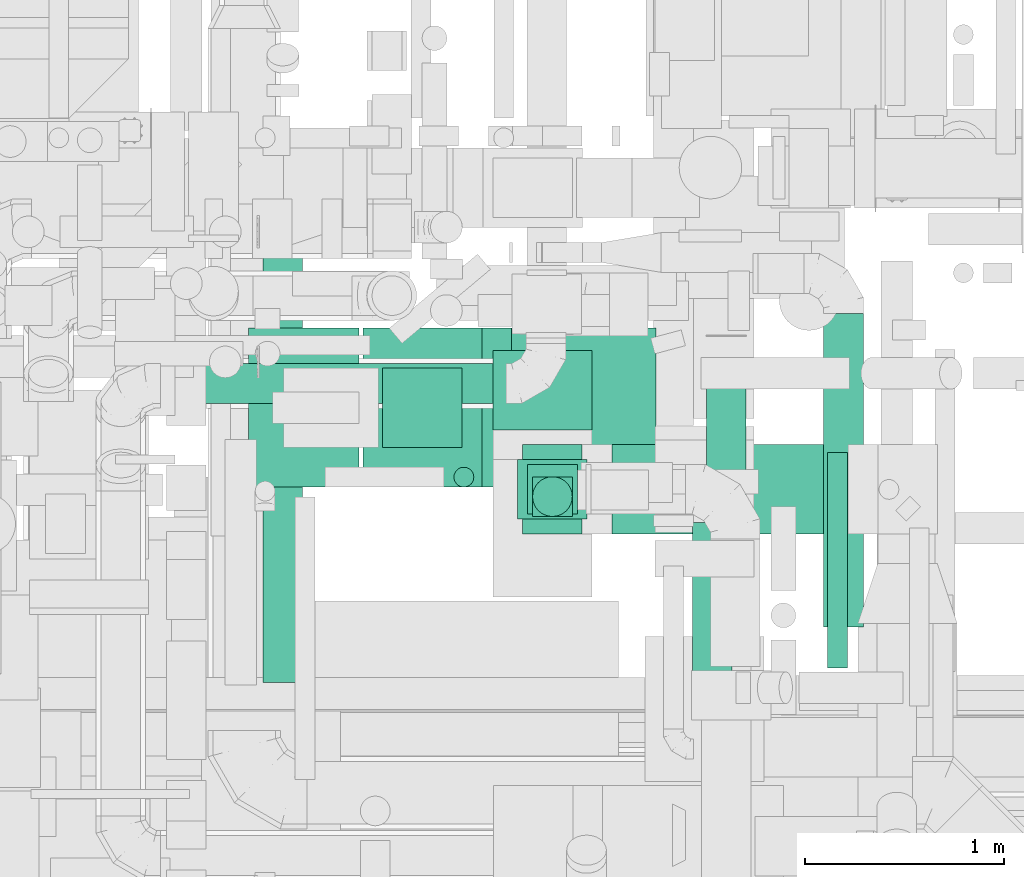
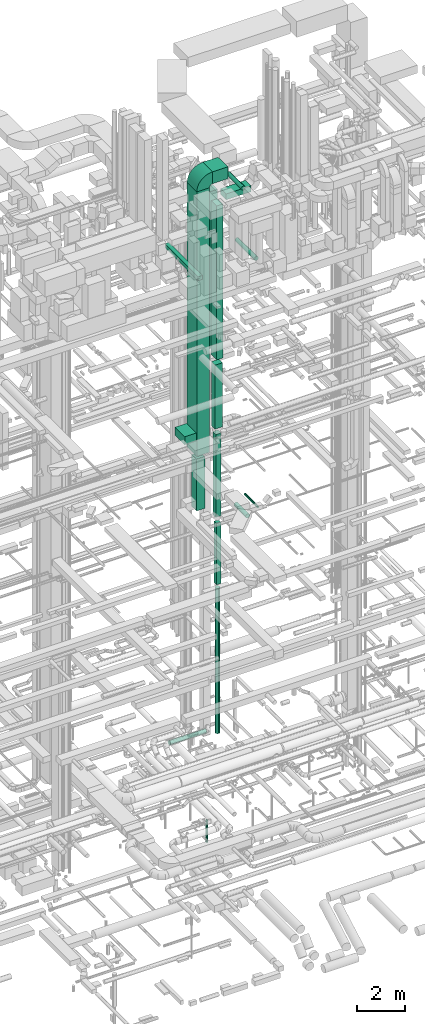
# One storey, part 45 of 337: 18 flow segments, 1 flow fitting.
"""IFC2X3 building model written with IfcOpenShell, lengths in millimetres."""

from ifc_helpers import new_model, entity, si_unit, converted_unit, derived_unit, direction, frame, frame_2d, origin, origin_2d_with_axis, place, context, subcontext, project, spatial, polyline, circle_curve, parameter, trimmed, segment, composite_curve, rectangle, circle, outline, extrude, source, transform, mapped, material, type_object, type_shapes, element, save


model = new_model("IFC2X3")

# Units and contexts
model_context = context("Model", 3, precision=0.01, world=origin(), true_north=direction((6.12303176911189e-17, 1.0)))
body_context = subcontext(model_context, "Body", "Model", "MODEL_VIEW")
ifc_project = project(units=[si_unit("LENGTHUNIT", "METRE", prefix="MILLI"), si_unit("AREAUNIT", "SQUARE_METRE"), si_unit("VOLUMEUNIT", "CUBIC_METRE"), converted_unit("PLANEANGLEUNIT", "DEGREE", entity("IfcRatioMeasure", 0.0174532925199433), si_unit("PLANEANGLEUNIT", "RADIAN"), dimensions=[0, 0, 0, 0, 0, 0, 0]), si_unit("MASSUNIT", "GRAM", prefix="KILO"), derived_unit("MASSDENSITYUNIT", [(si_unit("MASSUNIT", "GRAM", prefix="KILO"), 1), (si_unit("LENGTHUNIT", "METRE"), -3)]), derived_unit("MOMENTOFINERTIAUNIT", [(si_unit("LENGTHUNIT", "METRE"), 4)]), si_unit("TIMEUNIT", "SECOND"), si_unit("FREQUENCYUNIT", "HERTZ"), si_unit("THERMODYNAMICTEMPERATUREUNIT", "DEGREE_CELSIUS"), derived_unit("THERMALTRANSMITTANCEUNIT", [(si_unit("MASSUNIT", "GRAM", prefix="KILO"), 1), (si_unit("THERMODYNAMICTEMPERATUREUNIT", "KELVIN"), -1), (si_unit("TIMEUNIT", "SECOND"), -3)]), derived_unit("VOLUMETRICFLOWRATEUNIT", [(si_unit("LENGTHUNIT", "METRE"), 3), (si_unit("TIMEUNIT", "SECOND"), -1)]), derived_unit("MASSFLOWRATEUNIT", [(si_unit("MASSUNIT", "GRAM", prefix="KILO"), 1), (si_unit("TIMEUNIT", "SECOND"), -1)]), derived_unit("ROTATIONALFREQUENCYUNIT", [(si_unit("TIMEUNIT", "SECOND"), -1)]), si_unit("ELECTRICCURRENTUNIT", "AMPERE"), si_unit("ELECTRICVOLTAGEUNIT", "VOLT"), si_unit("POWERUNIT", "WATT"), si_unit("FORCEUNIT", "NEWTON", prefix="KILO"), si_unit("ILLUMINANCEUNIT", "LUX"), si_unit("LUMINOUSFLUXUNIT", "LUMEN"), si_unit("LUMINOUSINTENSITYUNIT", "CANDELA"), derived_unit("USERDEFINED", [(si_unit("MASSUNIT", "GRAM", prefix="KILO"), -1), (si_unit("LENGTHUNIT", "METRE"), -2), (si_unit("TIMEUNIT", "SECOND"), 3), (si_unit("LUMINOUSFLUXUNIT", "LUMEN"), 1)]), derived_unit("LINEARVELOCITYUNIT", [(si_unit("LENGTHUNIT", "METRE"), 1), (si_unit("TIMEUNIT", "SECOND"), -1)]), si_unit("PRESSUREUNIT", "PASCAL"), derived_unit("USERDEFINED", [(si_unit("LENGTHUNIT", "METRE"), -2), (si_unit("MASSUNIT", "GRAM", prefix="KILO"), 1), (si_unit("TIMEUNIT", "SECOND"), -2)]), derived_unit("LINEARFORCEUNIT", [(si_unit("MASSUNIT", "GRAM", prefix="KILO"), 1), (si_unit("LENGTHUNIT", "METRE"), 1), (si_unit("TIMEUNIT", "SECOND"), -2), (si_unit("LENGTHUNIT", "METRE"), -1)]), derived_unit("PLANARFORCEUNIT", [(si_unit("MASSUNIT", "GRAM", prefix="KILO"), 1), (si_unit("LENGTHUNIT", "METRE"), 1), (si_unit("TIMEUNIT", "SECOND"), -2), (si_unit("LENGTHUNIT", "METRE"), -2)])], contexts=[model_context])

# Site, building, storey
site_placement = place(None, origin())
site = spatial("IfcSite", under=ifc_project, at=site_placement, CompositionType="ELEMENT")
building_placement = place(site_placement, origin())
building = spatial("IfcBuilding", under=site, at=building_placement, CompositionType="ELEMENT")
storey_placement = place(building_placement, origin())
storey = spatial("IfcBuildingStorey", under=building, at=storey_placement, CompositionType="ELEMENT", Elevation=0.0)

# Flow segments
duct_segment_type_1 = type_object("IfcDuctSegmentType", PredefinedType="NOTDEFINED")
flow_segment_1_placement = place(storey_placement, frame((52500.03, 11137.23, 11150.0)))
element("IfcFlowSegment", 1, at=flow_segment_1_placement, inside=storey, type_object=duct_segment_type_1, context=body_context, shape_type="SweptSolid", body=[
    extrude(rectangle(XDim=200.000000000007, YDim=200.0, at=origin_2d_with_axis()), frame((100.0, 100.0, 0.0)), (0.0, 0.0, 1.0), 3100.00000000006),
])
flow_segment_2_placement = place(storey_placement, frame((51070.03, 11285.33, 18620.0)))
element("IfcFlowSegment", 2, at=flow_segment_2_placement, inside=storey, type_object=duct_segment_type_1, context=body_context, shape_type="SweptSolid", body=[
    extrude(rectangle(XDim=555.179984898517, YDim=800.0, at=origin_2d_with_axis()), frame((277.59, 400.0, 0.0)), (0.0, 0.0, 1.0), 400.0),
])
flow_segment_3_placement = place(storey_placement, frame((51645.21, 11285.34, 17827.47)))
element("IfcFlowSegment", 3, at=flow_segment_3_placement, inside=storey, type_object=duct_segment_type_1, context=body_context, shape_type="SweptSolid", body=[
    extrude(rectangle(XDim=600.000000000002, YDim=800.0, at=origin_2d_with_axis()), frame((300.0, 400.0, 0.0), z_axis=(0.0, 0.0, 1.0), x_axis=(-1.0, 0.0, 0.0)), (0.0, 0.0, 1.0), 13322.5290698006),
])
flow_segment_4_placement = place(storey_placement, frame((51745.21, 11485.34, 14927.47)))
element("IfcFlowSegment", 4, at=flow_segment_4_placement, inside=storey, type_object=duct_segment_type_1, context=body_context, shape_type="SweptSolid", body=[
    extrude(rectangle(XDim=399.999999999996, YDim=400.0, at=origin_2d_with_axis()), frame((200.0, 200.0, 0.0), z_axis=(0.0, 0.0, 1.0), x_axis=(-1.0, 0.0, 0.0)), (0.0, 0.0, 1.0), 2600.0),
])
flow_segment_5_placement = place(storey_placement, frame((52475.03, 11149.6, 14550.0)))
element("IfcFlowSegment", 5, at=flow_segment_5_placement, inside=storey, type_object=duct_segment_type_1, context=body_context, shape_type="SweptSolid", body=[
    extrude(rectangle(XDim=249.999999999999, YDim=250.000000000004, at=origin_2d_with_axis()), frame((125.0, 125.0, 0.0), z_axis=(0.0, 0.0, 1.0), x_axis=(0.0, 1.0, 0.0)), (0.0, 0.0, 1.0), 4175.39989839999),
])
flow_segment_6_placement = place(storey_placement, frame((52425.03, 11124.6, 19025.4)))
element("IfcFlowSegment", 6, at=flow_segment_6_placement, inside=storey, type_object=duct_segment_type_1, context=body_context, shape_type="SweptSolid", body=[
    extrude(rectangle(XDim=350.000000000007, YDim=300.000000000001, at=origin_2d_with_axis()), frame((175.0, 150.0, 0.0)), (0.0, 0.0, 1.0), 3224.60010159989),
])
flow_segment_7_placement = place(storey_placement, frame((52300.35, 11573.34, 22801.13)))
element("IfcFlowSegment", 7, at=flow_segment_7_placement, inside=storey, type_object=duct_segment_type_1, context=body_context, shape_type="SweptSolid", body=[
    extrude(rectangle(XDim=500.000000000008, YDim=400.000000000001, at=origin_2d_with_axis()), frame((250.0, 200.3, 0.01)), (0.0, 0.0, 1.0), 7903.89848948778),
])
flow_segment_8_placement = place(storey_placement, frame((51142.9, 10302.41, 27450.0)))
element("IfcFlowSegment", 8, at=flow_segment_8_placement, inside=storey, type_object=duct_segment_type_1, context=body_context, shape_type="SweptSolid", body=[
    extrude(rectangle(XDim=2749.99999999996, YDim=199.999999999998, at=origin_2d_with_axis()), frame((100.0, 1375.0, 0.0), z_axis=(0.0, 0.0, 1.0), x_axis=(0.0, -1.0, 0.0)), (0.0, 0.0, 1.0), 199.999999999998),
])
flow_segment_9_placement = place(storey_placement, frame((52395.21, 11285.34, 31300.0)))
element("IfcFlowSegment", 9, at=flow_segment_9_placement, inside=storey, type_object=duct_segment_type_1, context=body_context, shape_type="SweptSolid", body=[
    extrude(rectangle(XDim=725.900486099132, YDim=800.0, at=origin_2d_with_axis()), frame((362.95, 400.0, 0.0)), (0.0, 0.0, 1.0), 600.000000000002),
])
flow_segment_10_placement = place(storey_placement, frame((52450.03, 11049.6, 22550.0)))
element("IfcFlowSegment", 10, at=flow_segment_10_placement, inside=storey, type_object=duct_segment_type_1, context=body_context, shape_type="SweptSolid", body=[
    extrude(rectangle(XDim=300.000000000001, YDim=449.999999999999, at=origin_2d_with_axis()), frame((150.0, 225.0, 0.0)), (0.0, 0.0, 1.0), 7750.00000000012),
])
flow_segment_11_placement = place(storey_placement, frame((52900.03, 11049.6, 30450.0)))
element("IfcFlowSegment", 11, at=flow_segment_11_placement, inside=storey, type_object=duct_segment_type_1, context=body_context, shape_type="SweptSolid", body=[
    extrude(rectangle(XDim=1187.96669999977, YDim=449.999999999999, at=origin_2d_with_axis()), frame((593.98, 225.0, 0.0), z_axis=(0.0, 0.0, 1.0), x_axis=(-1.0, 0.0, 0.0)), (0.0, 0.0, 1.0), 300.000000000001),
])
duct_segment_type_2 = type_object("IfcDuctSegmentType", PredefinedType="NOTDEFINED")
flow_segment_12_placement = place(storey_placement, frame((52102.68, 11283.75, -1800.53)))
element("IfcFlowSegment", 12, at=flow_segment_12_placement, inside=storey, type_object=duct_segment_type_2, context=body_context, shape_type="SweptSolid", body=[
    extrude(circle(Radius=50.0, at=origin_2d_with_axis()), frame((51.6, 51.6, 0.0), z_axis=(0.0, 0.0, 1.0), x_axis=(-1.0, 0.0, 0.0)), (0.0, 0.0, 1.0), 1100.52558883259),
])
flow_segment_13_placement = place(storey_placement, frame((52498.44, 11135.63, 3630.0)))
element("IfcFlowSegment", 13, at=flow_segment_13_placement, inside=storey, type_object=duct_segment_type_2, context=body_context, shape_type="SweptSolid", body=[
    extrude(circle(Radius=100.0, at=origin_2d_with_axis()), frame((101.6, 101.6, 0.0)), (0.0, 0.0, 1.0), 7319.99999999999),
])
flow_segment_14_placement = place(storey_placement, frame((53303.43, 10130.34, 14818.4)))
element("IfcFlowSegment", 14, at=flow_segment_14_placement, inside=storey, type_object=duct_segment_type_2, context=body_context, shape_type="SweptSolid", body=[
    extrude(circle(Radius=100.0, at=origin_2d_with_axis()), frame((101.6, 0.0, 101.6), z_axis=(0.0, 1.0, 0.0), x_axis=(-1.0, 0.0, 0.0)), (0.0, 0.0, 1.0), 977.430276017839),
])
flow_segment_15_placement = place(storey_placement, frame((53984.44, 10375.04, 14948.4)))
element("IfcFlowSegment", 15, at=flow_segment_15_placement, inside=storey, type_object=duct_segment_type_2, context=body_context, shape_type="SweptSolid", body=[
    extrude(circle(Radius=50.0, at=origin_2d_with_axis()), frame((51.6, 0.0, 51.6), z_axis=(0.0, 1.0, 0.0), x_axis=(1.0, 0.0, 0.0)), (0.0, 0.0, 1.0), 1085.29999999999),
])
flow_segment_16_placement = place(storey_placement, frame((53373.44, 10626.24, 30998.4)))
element("IfcFlowSegment", 16, at=flow_segment_16_placement, inside=storey, type_object=duct_segment_type_2, context=body_context, shape_type="SweptSolid", body=[
    extrude(circle(Radius=100.0, at=origin_2d_with_axis()), frame((101.6, 0.0, 101.6), z_axis=(0.0, 1.0, 0.0), x_axis=(1.0, 0.0, 0.0)), (0.0, 0.0, 1.0), 1217.35789342062),
])
flow_segment_17_placement = place(storey_placement, frame((53964.22, 10580.01, 27273.4)))
element("IfcFlowSegment", 17, at=flow_segment_17_placement, inside=storey, type_object=duct_segment_type_2, context=body_context, shape_type="SweptSolid", body=[
    extrude(circle(Radius=100.0, at=origin_2d_with_axis()), frame((101.6, 0.0, 101.6), z_axis=(0.0, 1.0, 0.0), x_axis=(-1.0, 0.0, 0.0)), (0.0, 0.0, 1.0), 1580.00000000001),
])
flow_segment_18_placement = place(storey_placement, frame((50627.16, 11705.36, 3348.4)))
element("IfcFlowSegment", 18, at=flow_segment_18_placement, inside=storey, type_object=duct_segment_type_2, context=body_context, shape_type="SweptSolid", body=[
    extrude(circle(Radius=100.0, at=origin_2d_with_axis()), frame((0.0, 101.6, 101.6), z_axis=(1.0, 0.0, 0.0), x_axis=(0.0, -1.0, 0.0)), (0.0, 0.0, 1.0), 1740.00000000002),
])

# Flow fitting
ifc_material = material()
duct_fitting_type = type_object("IfcDuctFittingType", PredefinedType="NOTDEFINED", material=ifc_material)
shared_shape = source(origin(), body_context, "Body", "SweptSolid", [
    extrude(outline(composite_curve([segment(polyline([(-525.0, -225.0), (75.0, -225.0)]), True, "CONTINUOUS"), segment(trimmed(circle_curve(frame_2d((225.0, -225.0), x_axis=(0.0, 1.0)), 150.0), [parameter(0.0)], [parameter(90.0)], True, "PARAMETER"), False, "CONTINUOUS"), segment(polyline([(225.0, -75.0), (225.0, 525.0)]), True, "CONTINUOUS"), segment(trimmed(circle_curve(frame_2d((225.0, -225.0), x_axis=(0.0, 1.0)), 750.0), [parameter(0.0)], [parameter(90.0)], True, "PARAMETER"), True, "CONTINUOUS")], self_intersect=False)), frame((-225.0, 225.0, -400.0), z_axis=(0.0, 0.0, 1.0), x_axis=(-1.0, 0.0, 0.0)), (0.0, 0.0, 1.0), 800.0),
])
type_shapes(duct_fitting_type, [shared_shape])
flow_fitting_placement = place(storey_placement, frame((51945.21, 11685.34, 31600.0), z_axis=(0.0, 1.0, 0.0), x_axis=(0.0, 0.0, 1.0)))
element("IfcFlowFitting", 19, at=flow_fitting_placement, inside=storey, type_object=duct_fitting_type, material=ifc_material, context=body_context, shape_type="MappedRepresentation", body=[
    mapped(shared_shape, transform((0.0, 0.0, 0.0), scale=1.0)),
])

save(model, "model.ifc")
